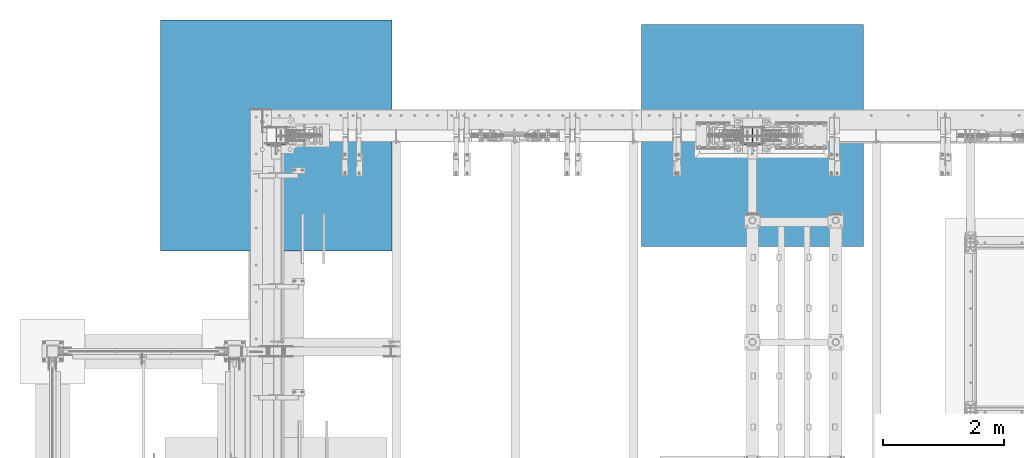
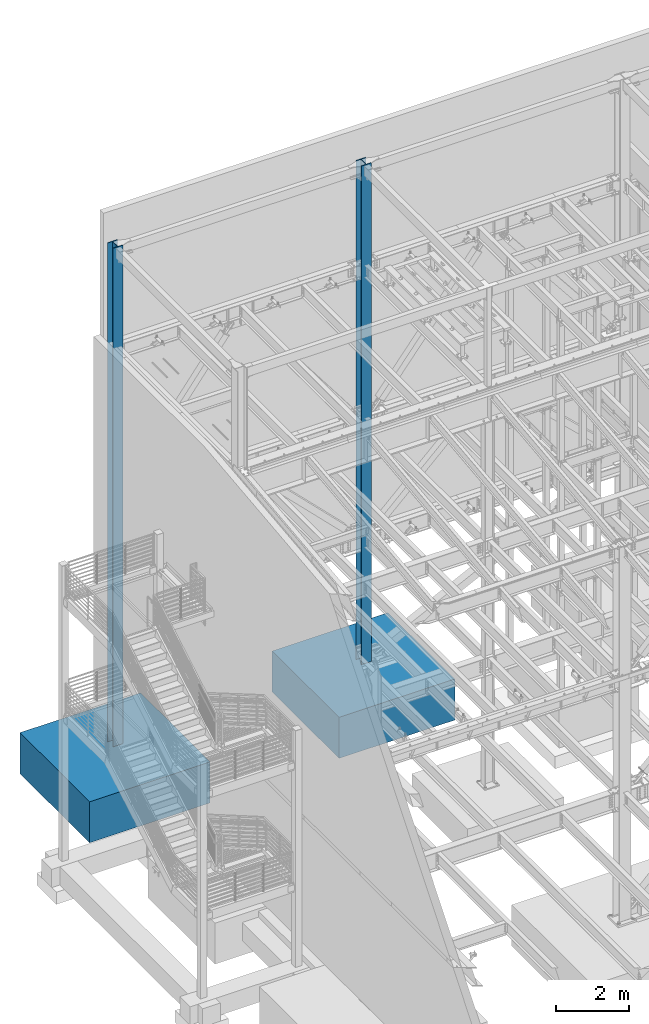
# One storey, part 369 of 1179: 4 columns, 4 elements without a shape of their own.
"""IFC2X3 building model written with IfcOpenShell, lengths in millimetres."""

from ifc_helpers import new_model, si_unit, frame, origin_with_axes, place, context, subcontext, project, spatial, faceted_brep, material, type_object, element, aggregate, save


model = new_model("IFC2X3")

# Units and contexts
model_context = context("Model", 3, precision=1e-05, world=origin_with_axes())
body_context = subcontext(model_context, "Body", "Model", "MODEL_VIEW")
ifc_project = project(units=[si_unit("LENGTHUNIT", "METRE", prefix="MILLI"), si_unit("AREAUNIT", "SQUARE_METRE"), si_unit("VOLUMEUNIT", "CUBIC_METRE"), si_unit("MASSUNIT", "GRAM", prefix="KILO"), si_unit("TIMEUNIT", "SECOND"), si_unit("PLANEANGLEUNIT", "RADIAN"), si_unit("SOLIDANGLEUNIT", "STERADIAN"), si_unit("THERMODYNAMICTEMPERATUREUNIT", "DEGREE_CELSIUS"), si_unit("LUMINOUSINTENSITYUNIT", "LUMEN")], contexts=[model_context])

# Site, building, storey
site_placement = place(None, origin_with_axes())
site = spatial("IfcSite", under=ifc_project, at=site_placement, CompositionType="ELEMENT")
building_placement = place(site_placement, origin_with_axes())
building = spatial("IfcBuilding", under=site, at=building_placement, Name="Undefined", CompositionType="ELEMENT")
storey_placement = place(building_placement, origin_with_axes())
storey = spatial("IfcBuildingStorey", under=building, at=storey_placement, Name="Undefined", CompositionType="ELEMENT", Elevation=0.0)

# Assembly, column
assembly_1_placement = place(storey_placement, origin_with_axes())
assembly_1 = element("IfcElementAssembly", 1, at=assembly_1_placement, inside=storey, Name="FOOTING", AssemblyPlace="NOTDEFINED", PredefinedType="REINFORCEMENT_UNIT")
ifc_material_1 = material(Name="CONCRETE/3000")
column_type_1 = type_object("IfcColumnType", PredefinedType="NOTDEFINED")
column_1_placement = place(assembly_1_placement, frame((8280.4, 41198.8, -1727.2), z_axis=(-1.0, 0.0, 0.0), x_axis=(0.0, 0.0, 1.0)))
column_1 = element("IfcColumn", 2, at=column_1_placement, type_object=column_type_1, material=ifc_material_1, Name="FOOTING", context=body_context, shape_type="Brep", body=[
    faceted_brep([(0.0, 1828.8, -1828.8), (0.0, 1828.8, 1828.8), (1371.6, 1828.8, 1828.8), (1371.6, 1828.8, -1828.8), (0.0, -1828.8, 1828.8), (1371.6, -1828.8, 1828.8), (0.0, -1828.8, -1828.8), (1371.6, -1828.8, -1828.8)], [[[0, 1, 2, 3]], [[1, 4, 5, 2]], [[4, 6, 7, 5]], [[6, 0, 3, 7]], [[5, 7, 3, 2]], [[6, 4, 1, 0]]]),
])
aggregate(assembly_1, [column_1])

assembly_2_placement = place(storey_placement, origin_with_axes())
assembly_2 = element("IfcElementAssembly", 3, at=assembly_2_placement, inside=storey, Name="FOOTING", AssemblyPlace="NOTDEFINED", PredefinedType="REINFORCEMENT_UNIT")
column_type_2 = type_object("IfcColumnType", PredefinedType="NOTDEFINED")
column_2_placement = place(assembly_2_placement, frame((431.8, 41198.8, -1727.2), z_axis=(-1.0, 0.0, 0.0), x_axis=(0.0, 0.0, 1.0)))
column_2 = element("IfcColumn", 4, at=column_2_placement, type_object=column_type_2, material=ifc_material_1, Name="FOOTING", context=body_context, shape_type="Brep", body=[
    faceted_brep([(0.0, 1905.0, -1905.0), (0.0, 1905.0, 1905.0), (1371.6, 1905.0, 1905.0), (1371.6, 1905.0, -1905.0), (0.0, -1905.0, 1905.0), (1371.6, -1905.0, 1905.0), (0.0, -1905.0, -1905.0), (1371.6, -1905.0, -1905.0)], [[[0, 1, 2, 3]], [[1, 4, 5, 2]], [[4, 6, 7, 5]], [[6, 0, 3, 7]], [[5, 7, 3, 2]], [[6, 4, 1, 0]]]),
])
aggregate(assembly_2, [column_2])

assembly_3_placement = place(storey_placement, origin_with_axes())
assembly_3 = element("IfcElementAssembly", 5, at=assembly_3_placement, inside=storey, Name="COLUMN", AssemblyPlace="NOTDEFINED", PredefinedType="RIGID_FRAME")
ifc_material_2 = material(Name="STEEL/A992")
column_type_3 = type_object("IfcColumnType", Name="W12X79", PredefinedType="NOTDEFINED")
column_3_placement = place(assembly_3_placement, frame((8280.4, 41198.8, -355.6), z_axis=(0.0, 1.0, 0.0), x_axis=(0.0, 0.0, 1.0)))
column_3 = element("IfcColumn", 6, at=column_3_placement, type_object=column_type_3, material=ifc_material_2, Name="COLUMN", ObjectType="W12X79", context=body_context, shape_type="Brep", body=[
    faceted_brep([(160.223581529497, -153.987499999999, 157.1625), (160.223581529497, 153.987499999999, 157.1625), (149.225002356772, 153.987499999999, 138.1125), (149.225002356772, 6.35000012494493, 138.1125), (148.995793121516, 6.35000012313685, 137.715499999996), (148.995793121516, -6.34999999999854, 137.715499999996), (149.225002356772, -6.34999999999854, 138.1125), (149.225002356772, -153.987499999999, 138.1125), (16814.8, 153.987500000003, -157.1625), (16814.8, -153.987500000003, -157.1625), (160.223597538519, -153.987499999999, -157.1625), (160.223597538519, 153.987499999999, -157.1625), (16814.8, -153.987500000003, -138.1125), (149.225402461476, -153.987499999999, -138.1125), (16814.8, -6.34999999999854, -138.1125), (149.225402461476, -6.34999999999854, -138.1125), (188.913, -6.34999999999854, 137.715499999996), (188.913, 6.35000008947463, 137.715499999996), (208.49066058208, 6.35000008789211, 131.2871410688), (208.49066058208, -6.34999999999854, 131.2871410688), (212.873373738864, 6.35000008718271, 128.290736246858), (212.873373738864, -6.34999999999854, 128.290736246858), (214.971292158606, 6.35000008606585, 123.413713099926), (214.971292158606, -6.34999999999854, 123.413713099926), (214.132634973196, 6.3500000848835, 118.171264187733), (214.132634973196, -6.34999999999854, 118.171264187733), (210.617956026487, 6.35000008400311, 114.192112472459), (210.617956026487, -6.34999999999854, 114.192112472459), (205.519195059062, 6.35000008370116, 112.712499999996), (205.519195059062, -6.34999999999854, 112.712499999996), (139.700000000001, 6.34999999999854, 112.7125), (147.032309983244, -6.35000007376584, 112.7125), (139.700000000001, 6.34999999999854, -112.7125), (147.032309983244, -6.35000000747095, -112.7125), (205.519195059063, 6.3500000365857, -112.712500000003), (205.519195059063, -6.34999999999854, -112.712500000003), (210.617956026486, 6.35000003621826, -114.192112472468), (210.617956026486, -6.34999999999854, -114.192112472468), (214.132634973195, 6.35000003529422, -118.171264187741), (214.132634973195, -6.34999999999854, -118.171264187741), (214.971292158605, 6.35000003410096, -123.413713099934), (214.971292158605, -6.34999999999854, -123.413713099934), (212.873373738863, 6.35000003300956, -128.290736246865), (212.873373738863, -6.34999999999854, -128.290736246865), (208.49066058208, 6.35000003235837, -131.287141068808), (208.49066058208, -6.34999999999854, -131.287141068808), (188.913, 6.35000003102323, -137.715500000003), (188.913, -6.34999999999854, -137.715500000003), (148.99620123074, 6.35000000162472, -137.715500000003), (148.99620123074, -6.34999999999854, -137.715500000003), (16814.8, 6.34999999999854, -138.1125), (16814.8, 153.987500000003, -138.1125), (149.225402461476, 153.987499999999, -138.1125), (149.225402461477, 6.34999999999854, -138.1125), (16814.8, 6.34999999999854, 138.1125), (16814.8, 153.987500000003, 138.1125), (16814.8, 153.987500000003, 157.1625), (16814.8, -153.987500000003, 157.1625), (16814.8, -153.987500000003, 138.1125), (16814.8, -6.34999999999854, 138.1125)], [[[0, 1, 2, 3, 4, 5, 6, 7]], [[8, 9, 10, 11]], [[9, 12, 13, 10]], [[12, 14, 15, 13]], [[16, 17, 18, 19]], [[19, 18, 20, 21]], [[21, 20, 22, 23]], [[23, 22, 24, 25]], [[25, 24, 26, 27]], [[27, 26, 28, 29]], [[29, 28, 30, 31]], [[32, 33, 31, 30]], [[33, 32, 34, 35]], [[35, 34, 36, 37]], [[37, 36, 38, 39]], [[39, 38, 40, 41]], [[41, 40, 42, 43]], [[43, 42, 44, 45]], [[45, 44, 46, 47]], [[47, 46, 48, 49]], [[50, 51, 52, 53]], [[10, 13, 15, 49, 48, 53, 52, 11]], [[51, 8, 11, 52]], [[50, 54, 55, 56, 57, 58, 59, 14, 12, 9, 8, 51]], [[58, 57, 0, 7]], [[59, 58, 7, 6]], [[16, 19, 21, 23, 25, 27, 29, 31, 33, 35, 37, 39, 41, 43, 45, 47, 49, 15, 14, 59, 6, 5]], [[17, 16, 5, 4]], [[54, 50, 53, 48, 46, 44, 42, 40, 38, 36, 34, 32, 30, 28, 26, 24, 22, 20, 18, 17, 4, 3]], [[55, 54, 3, 2]], [[56, 55, 2, 1]], [[57, 56, 1, 0]]]),
])
aggregate(assembly_3, [column_3])

assembly_4_placement = place(storey_placement, origin_with_axes())
assembly_4 = element("IfcElementAssembly", 7, at=assembly_4_placement, inside=storey, Name="COLUMN", AssemblyPlace="NOTDEFINED", PredefinedType="RIGID_FRAME")
column_4_placement = place(assembly_4_placement, frame((431.8, 41198.8, -355.6), z_axis=(0.0, 1.0, 0.0), x_axis=(0.0, 0.0, 1.0)))
column_4 = element("IfcColumn", 8, at=column_4_placement, type_object=column_type_3, material=ifc_material_2, Name="COLUMN", ObjectType="W12X79", context=body_context, shape_type="Brep", body=[
    faceted_brep([(160.223581529497, -153.987499999999, 157.1625), (160.223581529497, 153.987499999999, 157.1625), (149.225002356772, 153.987499999999, 138.1125), (149.225002356772, 6.35000012494493, 138.1125), (148.995793121516, 6.35000012313685, 137.715499999996), (148.995793121516, -6.34999999999854, 137.715499999996), (149.225002356772, -6.34999999999854, 138.1125), (149.225002356772, -153.987499999999, 138.1125), (16814.8, 153.987500000003, -157.1625), (16814.8, -153.987500000003, -157.1625), (160.223597538519, -153.987499999999, -157.1625), (160.223597538519, 153.987499999999, -157.1625), (16814.8, -153.987500000003, -138.1125), (149.225402461476, -153.987499999999, -138.1125), (16814.8, -6.34999999999854, -138.1125), (149.225402461476, -6.34999999999854, -138.1125), (188.913, -6.34999999999854, 137.715499999996), (188.913, 6.35000008947463, 137.715499999996), (208.49066058208, 6.35000008789211, 131.2871410688), (208.49066058208, -6.34999999999854, 131.2871410688), (212.873373738864, 6.35000008718271, 128.290736246858), (212.873373738864, -6.34999999999854, 128.290736246858), (214.971292158606, 6.35000008606585, 123.413713099926), (214.971292158606, -6.34999999999854, 123.413713099926), (214.132634973196, 6.3500000848835, 118.171264187733), (214.132634973196, -6.34999999999854, 118.171264187733), (210.617956026487, 6.35000008400311, 114.192112472459), (210.617956026487, -6.34999999999854, 114.192112472459), (205.519195059062, 6.35000008370116, 112.712499999996), (205.519195059062, -6.34999999999854, 112.712499999996), (139.700000000001, 6.34999999999854, 112.7125), (147.032309983244, -6.35000007376584, 112.7125), (139.700000000001, 6.34999999999854, -112.7125), (147.032309983244, -6.35000000747095, -112.7125), (205.519195059063, 6.3500000365857, -112.712500000003), (205.519195059063, -6.34999999999854, -112.712500000003), (210.617956026486, 6.35000003621826, -114.192112472468), (210.617956026486, -6.34999999999854, -114.192112472468), (214.132634973195, 6.35000003529422, -118.171264187741), (214.132634973195, -6.34999999999854, -118.171264187741), (214.971292158605, 6.35000003410096, -123.413713099934), (214.971292158605, -6.34999999999854, -123.413713099934), (212.873373738863, 6.35000003300956, -128.290736246865), (212.873373738863, -6.34999999999854, -128.290736246865), (208.49066058208, 6.35000003235837, -131.287141068808), (208.49066058208, -6.34999999999854, -131.287141068808), (188.913, 6.35000003102323, -137.715500000003), (188.913, -6.34999999999854, -137.715500000003), (148.99620123074, 6.35000000162472, -137.715500000003), (148.99620123074, -6.34999999999854, -137.715500000003), (16814.8, 6.34999999999854, -138.1125), (16814.8, 153.987500000003, -138.1125), (149.225402461476, 153.987499999999, -138.1125), (149.225402461477, 6.34999999999854, -138.1125), (16814.8, 6.34999999999854, 138.1125), (16814.8, 153.987500000003, 138.1125), (16814.8, 153.987500000003, 157.1625), (16814.8, -153.987500000003, 157.1625), (16814.8, -153.987500000003, 138.1125), (16814.8, -6.34999999999854, 138.1125)], [[[0, 1, 2, 3, 4, 5, 6, 7]], [[8, 9, 10, 11]], [[9, 12, 13, 10]], [[12, 14, 15, 13]], [[16, 17, 18, 19]], [[19, 18, 20, 21]], [[21, 20, 22, 23]], [[23, 22, 24, 25]], [[25, 24, 26, 27]], [[27, 26, 28, 29]], [[29, 28, 30, 31]], [[32, 33, 31, 30]], [[33, 32, 34, 35]], [[35, 34, 36, 37]], [[37, 36, 38, 39]], [[39, 38, 40, 41]], [[41, 40, 42, 43]], [[43, 42, 44, 45]], [[45, 44, 46, 47]], [[47, 46, 48, 49]], [[50, 51, 52, 53]], [[10, 13, 15, 49, 48, 53, 52, 11]], [[51, 8, 11, 52]], [[50, 54, 55, 56, 57, 58, 59, 14, 12, 9, 8, 51]], [[58, 57, 0, 7]], [[59, 58, 7, 6]], [[16, 19, 21, 23, 25, 27, 29, 31, 33, 35, 37, 39, 41, 43, 45, 47, 49, 15, 14, 59, 6, 5]], [[17, 16, 5, 4]], [[54, 50, 53, 48, 46, 44, 42, 40, 38, 36, 34, 32, 30, 28, 26, 24, 22, 20, 18, 17, 4, 3]], [[55, 54, 3, 2]], [[56, 55, 2, 1]], [[57, 56, 1, 0]]]),
])
aggregate(assembly_4, [column_4])

save(model, "model.ifc")
